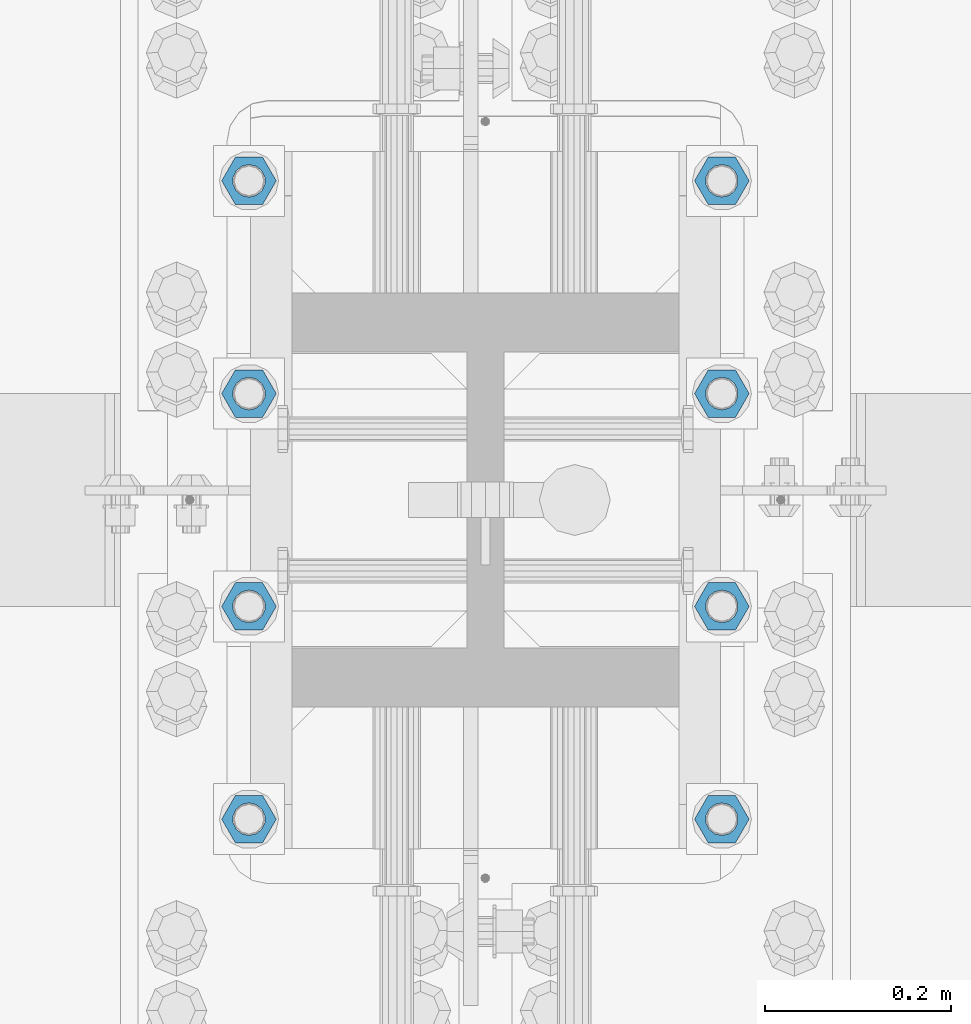
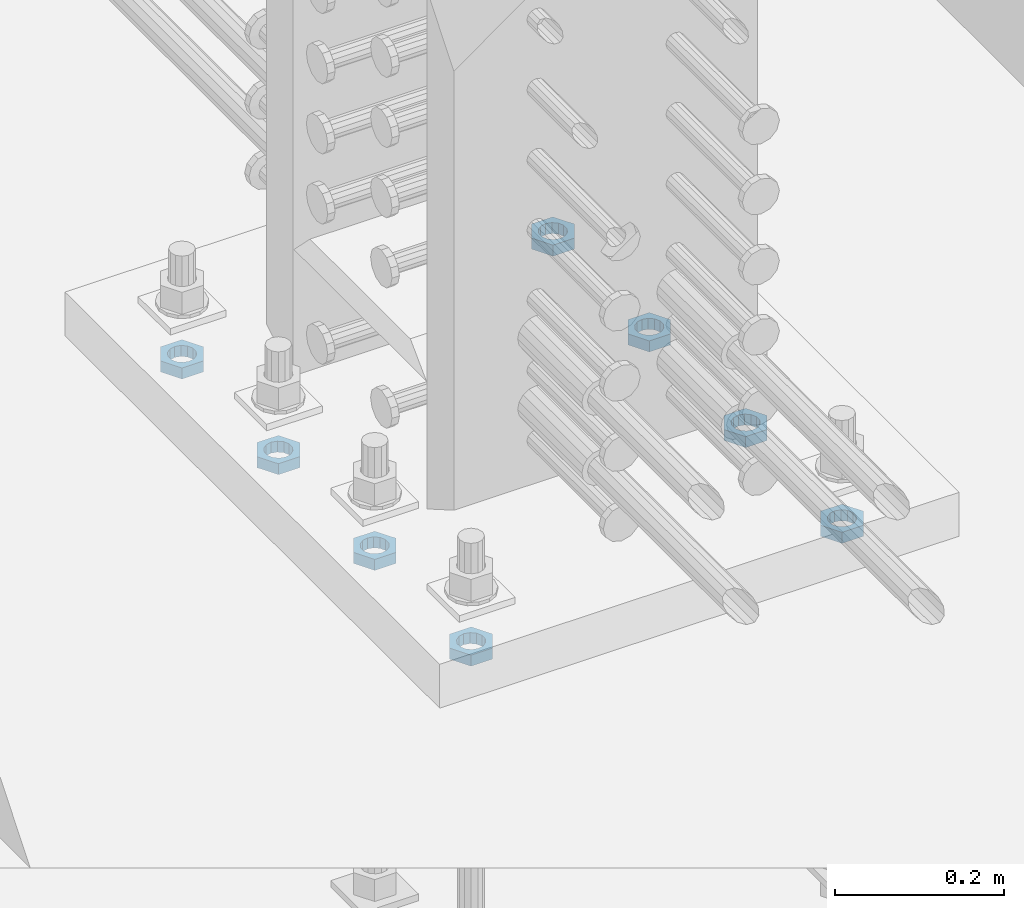
# One storey, part 1401 of 1763: 8 beams, 1 element without a shape of its own.
"""IFC2X3 building model written with IfcOpenShell, lengths in millimetres."""

from ifc_helpers import new_model, si_unit, frame, origin_with_axes, place, context, subcontext, project, spatial, faceted_brep, material, type_object, element, aggregate, save


model = new_model("IFC2X3")

# Units and contexts
model_context = context("Model", 3, precision=1e-05, world=origin_with_axes())
body_context = subcontext(model_context, "Body", "Model", "MODEL_VIEW")
ifc_project = project(units=[si_unit("LENGTHUNIT", "METRE", prefix="MILLI"), si_unit("AREAUNIT", "SQUARE_METRE"), si_unit("VOLUMEUNIT", "CUBIC_METRE"), si_unit("MASSUNIT", "GRAM", prefix="KILO"), si_unit("TIMEUNIT", "SECOND"), si_unit("PLANEANGLEUNIT", "RADIAN"), si_unit("SOLIDANGLEUNIT", "STERADIAN"), si_unit("THERMODYNAMICTEMPERATUREUNIT", "DEGREE_CELSIUS"), si_unit("LUMINOUSINTENSITYUNIT", "LUMEN")], contexts=[model_context])

# Site, building, storey
site_placement = place(None, origin_with_axes())
site = spatial("IfcSite", under=ifc_project, at=site_placement, CompositionType="ELEMENT")
building_placement = place(site_placement, origin_with_axes())
building = spatial("IfcBuilding", under=site, at=building_placement, Name="Undefined", CompositionType="ELEMENT")
storey_placement = place(building_placement, origin_with_axes())
storey = spatial("IfcBuildingStorey", under=building, at=storey_placement, Name="Undefined", CompositionType="ELEMENT", Elevation=0.0)

# Assembly, beams
assembly_placement = place(storey_placement, origin_with_axes())
assembly = element("IfcElementAssembly", 1, at=assembly_placement, inside=storey, Name="TEMPLATE", AssemblyPlace="NOTDEFINED", PredefinedType="RIGID_FRAME")
ifc_material = material(Name="STEEL/A563")
beam_type = type_object("IfcBeamType", Name="1-1/4_DIA. HALF_NUT", PredefinedType="NOTDEFINED")
beam_1_placement = place(assembly_placement, frame((-24281.8372736984, 800.099999999999, 3848.1), z_axis=(0.0, -1.0, 0.0), x_axis=(0.0, 0.0, -1.0)))
beam_1 = element("IfcBeam", 2, at=beam_1_placement, type_object=beam_type, material=ifc_material, Name="NUT", ObjectType="1-1/4_DIA. HALF_NUT", context=body_context, shape_type="Brep", body=[
    faceted_brep([(0.0, -29.3700008392334, 0.0), (0.0, -14.6800003051758, -25.4300003051758), (15.875, -14.6800003051758, -25.4300003051758), (15.875, -29.3700008392334, 0.0), (0.0, 14.6800003051758, -25.4300003051758), (15.875, 14.6800003051758, -25.4300003051758), (0.0, 29.3700008392334, 0.0), (15.875, 29.3700008392334, 0.0), (0.0, 14.6800003051758, 25.4300003051758), (15.875, 14.6800003051758, 25.4300003051758), (0.0, -14.6800003051758, 25.4300003051758), (15.875, -14.6800003051758, 25.4300003051758), (0.0, 0.0, 17.4599990844727), (0.0, 7.57560968776022, 15.730915608714), (15.875, 7.57560968776022, 15.730915608714), (15.875, 0.0, 17.4599990844727), (0.0, 13.6507769681037, 10.8861313696252), (15.875, 13.6507769681037, 10.8861313696252), (0.0, 17.0222404541215, 3.88521530314756), (15.875, 17.0222404541215, 3.88521530314756), (0.0, 17.0222404541215, -3.88521530314756), (15.875, 17.0222404541215, -3.88521530314756), (0.0, 13.6507769681037, -10.8861313696252), (15.875, 13.6507769681037, -10.8861313696252), (0.0, 7.57560968776022, -15.730915608714), (15.875, 7.57560968776022, -15.730915608714), (0.0, 0.0, -17.4599990844727), (15.875, 0.0, -17.4599990844727), (0.0, -7.57560968776022, -15.730915608714), (15.875, -7.57560968776022, -15.730915608714), (0.0, -13.6507769681037, -10.8861313696252), (15.875, -13.6507769681037, -10.8861313696252), (0.0, -17.0222404541215, -3.88521530314756), (15.875, -17.0222404541215, -3.88521530314756), (0.0, -17.0222404541215, 3.88521530314756), (15.875, -17.0222404541215, 3.88521530314756), (0.0, -13.6507769681037, 10.8861313696252), (15.875, -13.6507769681037, 10.8861313696252), (0.0, -7.57560968776022, 15.730915608714), (15.875, -7.57560968776022, 15.730915608714)], [[[0, 1, 2, 3]], [[1, 4, 5, 2]], [[4, 6, 7, 5]], [[6, 8, 9, 7]], [[8, 10, 11, 9]], [[10, 0, 3, 11]], [[12, 13, 14, 15]], [[13, 16, 17, 14]], [[16, 18, 19, 17]], [[18, 20, 21, 19]], [[20, 22, 23, 21]], [[22, 24, 25, 23]], [[24, 26, 27, 25]], [[26, 28, 29, 27]], [[28, 30, 31, 29]], [[30, 32, 33, 31]], [[32, 34, 35, 33]], [[34, 36, 37, 35]], [[36, 38, 39, 37]], [[38, 12, 15, 39]], [[5, 7, 9, 11, 3, 2], [17, 19, 21, 23, 25, 27, 29, 31, 33, 35, 37, 39, 15, 14]], [[10, 8, 6, 4, 1, 0], [38, 36, 34, 32, 30, 28, 26, 24, 22, 20, 18, 16, 13, 12]]]),
])
beam_2_placement = place(assembly_placement, frame((-23773.8372736984, 800.099999999999, 3848.1), z_axis=(0.0, 1.0, 0.0), x_axis=(0.0, 0.0, -1.0)))
beam_2 = element("IfcBeam", 3, at=beam_2_placement, type_object=beam_type, material=ifc_material, Name="NUT", ObjectType="1-1/4_DIA. HALF_NUT", context=body_context, shape_type="Brep", body=[
    faceted_brep([(0.0, -29.3700008392334, 0.0), (0.0, -14.6800003051758, -25.4300003051758), (15.875, -14.6800003051758, -25.4300003051758), (15.875, -29.3700008392334, 0.0), (0.0, 14.6800003051758, -25.4300003051758), (15.875, 14.6800003051758, -25.4300003051758), (0.0, 29.3700008392334, 0.0), (15.875, 29.3700008392334, 0.0), (0.0, 14.6800003051758, 25.4300003051758), (15.875, 14.6800003051758, 25.4300003051758), (0.0, -14.6800003051758, 25.4300003051758), (15.875, -14.6800003051758, 25.4300003051758), (0.0, 0.0, 17.4599990844727), (0.0, 7.57560968776022, 15.730915608714), (15.875, 7.57560968776022, 15.730915608714), (15.875, 0.0, 17.4599990844727), (0.0, 13.6507769681037, 10.8861313696252), (15.875, 13.6507769681037, 10.8861313696252), (0.0, 17.0222404541215, 3.88521530314756), (15.875, 17.0222404541215, 3.88521530314756), (0.0, 17.0222404541215, -3.88521530314756), (15.875, 17.0222404541215, -3.88521530314756), (0.0, 13.6507769681037, -10.8861313696252), (15.875, 13.6507769681037, -10.8861313696252), (0.0, 7.57560968776022, -15.730915608714), (15.875, 7.57560968776022, -15.730915608714), (0.0, 0.0, -17.4599990844727), (15.875, 0.0, -17.4599990844727), (0.0, -7.57560968776022, -15.730915608714), (15.875, -7.57560968776022, -15.730915608714), (0.0, -13.6507769681037, -10.8861313696252), (15.875, -13.6507769681037, -10.8861313696252), (0.0, -17.0222404541215, -3.88521530314756), (15.875, -17.0222404541215, -3.88521530314756), (0.0, -17.0222404541215, 3.88521530314756), (15.875, -17.0222404541215, 3.88521530314756), (0.0, -13.6507769681037, 10.8861313696252), (15.875, -13.6507769681037, 10.8861313696252), (0.0, -7.57560968776022, 15.730915608714), (15.875, -7.57560968776022, 15.730915608714)], [[[0, 1, 2, 3]], [[1, 4, 5, 2]], [[4, 6, 7, 5]], [[6, 8, 9, 7]], [[8, 10, 11, 9]], [[10, 0, 3, 11]], [[12, 13, 14, 15]], [[13, 16, 17, 14]], [[16, 18, 19, 17]], [[18, 20, 21, 19]], [[20, 22, 23, 21]], [[22, 24, 25, 23]], [[24, 26, 27, 25]], [[26, 28, 29, 27]], [[28, 30, 31, 29]], [[30, 32, 33, 31]], [[32, 34, 35, 33]], [[34, 36, 37, 35]], [[36, 38, 39, 37]], [[38, 12, 15, 39]], [[5, 7, 9, 11, 3, 2], [17, 19, 21, 23, 25, 27, 29, 31, 33, 35, 37, 39, 15, 14]], [[10, 8, 6, 4, 1, 0], [38, 36, 34, 32, 30, 28, 26, 24, 22, 20, 18, 16, 13, 12]]]),
])
beam_3_placement = place(assembly_placement, frame((-24281.8372736984, 571.499999999998, 3848.1), z_axis=(0.0, -1.0, 0.0), x_axis=(0.0, 0.0, -1.0)))
beam_3 = element("IfcBeam", 4, at=beam_3_placement, type_object=beam_type, material=ifc_material, Name="NUT", ObjectType="1-1/4_DIA. HALF_NUT", context=body_context, shape_type="Brep", body=[
    faceted_brep([(0.0, -29.3700008392334, 0.0), (0.0, -14.6800003051758, -25.4300003051758), (15.875, -14.6800003051758, -25.4300003051758), (15.875, -29.3700008392334, 0.0), (0.0, 14.6800003051758, -25.4300003051758), (15.875, 14.6800003051758, -25.4300003051758), (0.0, 29.3700008392334, 0.0), (15.875, 29.3700008392334, 0.0), (0.0, 14.6800003051758, 25.4300003051758), (15.875, 14.6800003051758, 25.4300003051758), (0.0, -14.6800003051758, 25.4300003051758), (15.875, -14.6800003051758, 25.4300003051758), (0.0, 0.0, 17.4599990844727), (0.0, 7.57560968776022, 15.730915608714), (15.875, 7.57560968776022, 15.730915608714), (15.875, 0.0, 17.4599990844727), (0.0, 13.6507769681037, 10.8861313696252), (15.875, 13.6507769681037, 10.8861313696252), (0.0, 17.0222404541215, 3.88521530314756), (15.875, 17.0222404541215, 3.88521530314756), (0.0, 17.0222404541215, -3.88521530314756), (15.875, 17.0222404541215, -3.88521530314756), (0.0, 13.6507769681037, -10.8861313696252), (15.875, 13.6507769681037, -10.8861313696252), (0.0, 7.57560968776022, -15.730915608714), (15.875, 7.57560968776022, -15.730915608714), (0.0, 0.0, -17.4599990844727), (15.875, 0.0, -17.4599990844727), (0.0, -7.57560968776022, -15.730915608714), (15.875, -7.57560968776022, -15.730915608714), (0.0, -13.6507769681037, -10.8861313696252), (15.875, -13.6507769681037, -10.8861313696252), (0.0, -17.0222404541215, -3.88521530314756), (15.875, -17.0222404541215, -3.88521530314756), (0.0, -17.0222404541215, 3.88521530314756), (15.875, -17.0222404541215, 3.88521530314756), (0.0, -13.6507769681037, 10.8861313696252), (15.875, -13.6507769681037, 10.8861313696252), (0.0, -7.57560968776022, 15.730915608714), (15.875, -7.57560968776022, 15.730915608714)], [[[0, 1, 2, 3]], [[1, 4, 5, 2]], [[4, 6, 7, 5]], [[6, 8, 9, 7]], [[8, 10, 11, 9]], [[10, 0, 3, 11]], [[12, 13, 14, 15]], [[13, 16, 17, 14]], [[16, 18, 19, 17]], [[18, 20, 21, 19]], [[20, 22, 23, 21]], [[22, 24, 25, 23]], [[24, 26, 27, 25]], [[26, 28, 29, 27]], [[28, 30, 31, 29]], [[30, 32, 33, 31]], [[32, 34, 35, 33]], [[34, 36, 37, 35]], [[36, 38, 39, 37]], [[38, 12, 15, 39]], [[5, 7, 9, 11, 3, 2], [17, 19, 21, 23, 25, 27, 29, 31, 33, 35, 37, 39, 15, 14]], [[10, 8, 6, 4, 1, 0], [38, 36, 34, 32, 30, 28, 26, 24, 22, 20, 18, 16, 13, 12]]]),
])
beam_4_placement = place(assembly_placement, frame((-23773.8372736984, 571.499999999998, 3848.1), z_axis=(0.0, 1.0, 0.0), x_axis=(0.0, 0.0, -1.0)))
beam_4 = element("IfcBeam", 5, at=beam_4_placement, type_object=beam_type, material=ifc_material, Name="NUT", ObjectType="1-1/4_DIA. HALF_NUT", context=body_context, shape_type="Brep", body=[
    faceted_brep([(0.0, -29.3700008392334, 0.0), (0.0, -14.6800003051758, -25.4300003051758), (15.875, -14.6800003051758, -25.4300003051758), (15.875, -29.3700008392334, 0.0), (0.0, 14.6800003051758, -25.4300003051758), (15.875, 14.6800003051758, -25.4300003051758), (0.0, 29.3700008392334, 0.0), (15.875, 29.3700008392334, 0.0), (0.0, 14.6800003051758, 25.4300003051758), (15.875, 14.6800003051758, 25.4300003051758), (0.0, -14.6800003051758, 25.4300003051758), (15.875, -14.6800003051758, 25.4300003051758), (0.0, 0.0, 17.4599990844727), (0.0, 7.57560968776022, 15.730915608714), (15.875, 7.57560968776022, 15.730915608714), (15.875, 0.0, 17.4599990844727), (0.0, 13.6507769681037, 10.8861313696252), (15.875, 13.6507769681037, 10.8861313696252), (0.0, 17.0222404541215, 3.88521530314756), (15.875, 17.0222404541215, 3.88521530314756), (0.0, 17.0222404541215, -3.88521530314756), (15.875, 17.0222404541215, -3.88521530314756), (0.0, 13.6507769681037, -10.8861313696252), (15.875, 13.6507769681037, -10.8861313696252), (0.0, 7.57560968776022, -15.730915608714), (15.875, 7.57560968776022, -15.730915608714), (0.0, 0.0, -17.4599990844727), (15.875, 0.0, -17.4599990844727), (0.0, -7.57560968776022, -15.730915608714), (15.875, -7.57560968776022, -15.730915608714), (0.0, -13.6507769681037, -10.8861313696252), (15.875, -13.6507769681037, -10.8861313696252), (0.0, -17.0222404541215, -3.88521530314756), (15.875, -17.0222404541215, -3.88521530314756), (0.0, -17.0222404541215, 3.88521530314756), (15.875, -17.0222404541215, 3.88521530314756), (0.0, -13.6507769681037, 10.8861313696252), (15.875, -13.6507769681037, 10.8861313696252), (0.0, -7.57560968776022, 15.730915608714), (15.875, -7.57560968776022, 15.730915608714)], [[[0, 1, 2, 3]], [[1, 4, 5, 2]], [[4, 6, 7, 5]], [[6, 8, 9, 7]], [[8, 10, 11, 9]], [[10, 0, 3, 11]], [[12, 13, 14, 15]], [[13, 16, 17, 14]], [[16, 18, 19, 17]], [[18, 20, 21, 19]], [[20, 22, 23, 21]], [[22, 24, 25, 23]], [[24, 26, 27, 25]], [[26, 28, 29, 27]], [[28, 30, 31, 29]], [[30, 32, 33, 31]], [[32, 34, 35, 33]], [[34, 36, 37, 35]], [[36, 38, 39, 37]], [[38, 12, 15, 39]], [[5, 7, 9, 11, 3, 2], [17, 19, 21, 23, 25, 27, 29, 31, 33, 35, 37, 39, 15, 14]], [[10, 8, 6, 4, 1, 0], [38, 36, 34, 32, 30, 28, 26, 24, 22, 20, 18, 16, 13, 12]]]),
])
beam_5_placement = place(assembly_placement, frame((-23773.8372736984, 342.899999999998, 3848.1), z_axis=(0.0, 1.0, 0.0), x_axis=(0.0, 0.0, -1.0)))
beam_5 = element("IfcBeam", 6, at=beam_5_placement, type_object=beam_type, material=ifc_material, Name="NUT", ObjectType="1-1/4_DIA. HALF_NUT", context=body_context, shape_type="Brep", body=[
    faceted_brep([(0.0, -29.3700008392334, 0.0), (0.0, -14.6800003051758, -25.4300003051758), (15.875, -14.6800003051758, -25.4300003051758), (15.875, -29.3700008392334, 0.0), (0.0, 14.6800003051758, -25.4300003051758), (15.875, 14.6800003051758, -25.4300003051758), (0.0, 29.3700008392334, 0.0), (15.875, 29.3700008392334, 0.0), (0.0, 14.6800003051758, 25.4300003051758), (15.875, 14.6800003051758, 25.4300003051758), (0.0, -14.6800003051758, 25.4300003051758), (15.875, -14.6800003051758, 25.4300003051758), (0.0, 0.0, 17.4599990844727), (0.0, 7.57560968776022, 15.730915608714), (15.875, 7.57560968776022, 15.730915608714), (15.875, 0.0, 17.4599990844727), (0.0, 13.6507769681037, 10.8861313696252), (15.875, 13.6507769681037, 10.8861313696252), (0.0, 17.0222404541215, 3.88521530314756), (15.875, 17.0222404541215, 3.88521530314756), (0.0, 17.0222404541215, -3.88521530314756), (15.875, 17.0222404541215, -3.88521530314756), (0.0, 13.6507769681037, -10.8861313696252), (15.875, 13.6507769681037, -10.8861313696252), (0.0, 7.57560968776022, -15.730915608714), (15.875, 7.57560968776022, -15.730915608714), (0.0, 0.0, -17.4599990844727), (15.875, 0.0, -17.4599990844727), (0.0, -7.57560968776022, -15.730915608714), (15.875, -7.57560968776022, -15.730915608714), (0.0, -13.6507769681037, -10.8861313696252), (15.875, -13.6507769681037, -10.8861313696252), (0.0, -17.0222404541215, -3.88521530314756), (15.875, -17.0222404541215, -3.88521530314756), (0.0, -17.0222404541215, 3.88521530314756), (15.875, -17.0222404541215, 3.88521530314756), (0.0, -13.6507769681037, 10.8861313696252), (15.875, -13.6507769681037, 10.8861313696252), (0.0, -7.57560968776022, 15.730915608714), (15.875, -7.57560968776022, 15.730915608714)], [[[0, 1, 2, 3]], [[1, 4, 5, 2]], [[4, 6, 7, 5]], [[6, 8, 9, 7]], [[8, 10, 11, 9]], [[10, 0, 3, 11]], [[12, 13, 14, 15]], [[13, 16, 17, 14]], [[16, 18, 19, 17]], [[18, 20, 21, 19]], [[20, 22, 23, 21]], [[22, 24, 25, 23]], [[24, 26, 27, 25]], [[26, 28, 29, 27]], [[28, 30, 31, 29]], [[30, 32, 33, 31]], [[32, 34, 35, 33]], [[34, 36, 37, 35]], [[36, 38, 39, 37]], [[38, 12, 15, 39]], [[5, 7, 9, 11, 3, 2], [17, 19, 21, 23, 25, 27, 29, 31, 33, 35, 37, 39, 15, 14]], [[10, 8, 6, 4, 1, 0], [38, 36, 34, 32, 30, 28, 26, 24, 22, 20, 18, 16, 13, 12]]]),
])
beam_6_placement = place(assembly_placement, frame((-24281.8372736984, 342.899999999998, 3848.1), z_axis=(0.0, -1.0, 0.0), x_axis=(0.0, 0.0, -1.0)))
beam_6 = element("IfcBeam", 7, at=beam_6_placement, type_object=beam_type, material=ifc_material, Name="NUT", ObjectType="1-1/4_DIA. HALF_NUT", context=body_context, shape_type="Brep", body=[
    faceted_brep([(0.0, -29.3700008392334, 0.0), (0.0, -14.6800003051758, -25.4300003051758), (15.875, -14.6800003051758, -25.4300003051758), (15.875, -29.3700008392334, 0.0), (0.0, 14.6800003051758, -25.4300003051758), (15.875, 14.6800003051758, -25.4300003051758), (0.0, 29.3700008392334, 0.0), (15.875, 29.3700008392334, 0.0), (0.0, 14.6800003051758, 25.4300003051758), (15.875, 14.6800003051758, 25.4300003051758), (0.0, -14.6800003051758, 25.4300003051758), (15.875, -14.6800003051758, 25.4300003051758), (0.0, 0.0, 17.4599990844727), (0.0, 7.57560968776022, 15.730915608714), (15.875, 7.57560968776022, 15.730915608714), (15.875, 0.0, 17.4599990844727), (0.0, 13.6507769681037, 10.8861313696252), (15.875, 13.6507769681037, 10.8861313696252), (0.0, 17.0222404541215, 3.88521530314756), (15.875, 17.0222404541215, 3.88521530314756), (0.0, 17.0222404541215, -3.88521530314756), (15.875, 17.0222404541215, -3.88521530314756), (0.0, 13.6507769681037, -10.8861313696252), (15.875, 13.6507769681037, -10.8861313696252), (0.0, 7.57560968776022, -15.730915608714), (15.875, 7.57560968776022, -15.730915608714), (0.0, 0.0, -17.4599990844727), (15.875, 0.0, -17.4599990844727), (0.0, -7.57560968776022, -15.730915608714), (15.875, -7.57560968776022, -15.730915608714), (0.0, -13.6507769681037, -10.8861313696252), (15.875, -13.6507769681037, -10.8861313696252), (0.0, -17.0222404541215, -3.88521530314756), (15.875, -17.0222404541215, -3.88521530314756), (0.0, -17.0222404541215, 3.88521530314756), (15.875, -17.0222404541215, 3.88521530314756), (0.0, -13.6507769681037, 10.8861313696252), (15.875, -13.6507769681037, 10.8861313696252), (0.0, -7.57560968776022, 15.730915608714), (15.875, -7.57560968776022, 15.730915608714)], [[[0, 1, 2, 3]], [[1, 4, 5, 2]], [[4, 6, 7, 5]], [[6, 8, 9, 7]], [[8, 10, 11, 9]], [[10, 0, 3, 11]], [[12, 13, 14, 15]], [[13, 16, 17, 14]], [[16, 18, 19, 17]], [[18, 20, 21, 19]], [[20, 22, 23, 21]], [[22, 24, 25, 23]], [[24, 26, 27, 25]], [[26, 28, 29, 27]], [[28, 30, 31, 29]], [[30, 32, 33, 31]], [[32, 34, 35, 33]], [[34, 36, 37, 35]], [[36, 38, 39, 37]], [[38, 12, 15, 39]], [[5, 7, 9, 11, 3, 2], [17, 19, 21, 23, 25, 27, 29, 31, 33, 35, 37, 39, 15, 14]], [[10, 8, 6, 4, 1, 0], [38, 36, 34, 32, 30, 28, 26, 24, 22, 20, 18, 16, 13, 12]]]),
])
beam_7_placement = place(assembly_placement, frame((-24281.8372736984, 114.299999999997, 3848.1), z_axis=(0.0, -1.0, 0.0), x_axis=(0.0, 0.0, -1.0)))
beam_7 = element("IfcBeam", 8, at=beam_7_placement, type_object=beam_type, material=ifc_material, Name="NUT", ObjectType="1-1/4_DIA. HALF_NUT", context=body_context, shape_type="Brep", body=[
    faceted_brep([(0.0, -29.3700008392334, 0.0), (0.0, -14.6800003051758, -25.4300003051758), (15.875, -14.6800003051758, -25.4300003051758), (15.875, -29.3700008392334, 0.0), (0.0, 14.6800003051758, -25.4300003051758), (15.875, 14.6800003051758, -25.4300003051758), (0.0, 29.3700008392334, 0.0), (15.875, 29.3700008392334, 0.0), (0.0, 14.6800003051758, 25.4300003051758), (15.875, 14.6800003051758, 25.4300003051758), (0.0, -14.6800003051758, 25.4300003051758), (15.875, -14.6800003051758, 25.4300003051758), (0.0, 0.0, 17.4599990844727), (0.0, 7.57560968776022, 15.730915608714), (15.875, 7.57560968776022, 15.730915608714), (15.875, 0.0, 17.4599990844727), (0.0, 13.6507769681037, 10.8861313696252), (15.875, 13.6507769681037, 10.8861313696252), (0.0, 17.0222404541215, 3.88521530314756), (15.875, 17.0222404541215, 3.88521530314756), (0.0, 17.0222404541215, -3.88521530314756), (15.875, 17.0222404541215, -3.88521530314756), (0.0, 13.6507769681037, -10.8861313696252), (15.875, 13.6507769681037, -10.8861313696252), (0.0, 7.57560968776022, -15.730915608714), (15.875, 7.57560968776022, -15.730915608714), (0.0, 0.0, -17.4599990844727), (15.875, 0.0, -17.4599990844727), (0.0, -7.57560968776022, -15.730915608714), (15.875, -7.57560968776022, -15.730915608714), (0.0, -13.6507769681037, -10.8861313696252), (15.875, -13.6507769681037, -10.8861313696252), (0.0, -17.0222404541215, -3.88521530314756), (15.875, -17.0222404541215, -3.88521530314756), (0.0, -17.0222404541215, 3.88521530314756), (15.875, -17.0222404541215, 3.88521530314756), (0.0, -13.6507769681037, 10.8861313696252), (15.875, -13.6507769681037, 10.8861313696252), (0.0, -7.57560968776022, 15.730915608714), (15.875, -7.57560968776022, 15.730915608714)], [[[0, 1, 2, 3]], [[1, 4, 5, 2]], [[4, 6, 7, 5]], [[6, 8, 9, 7]], [[8, 10, 11, 9]], [[10, 0, 3, 11]], [[12, 13, 14, 15]], [[13, 16, 17, 14]], [[16, 18, 19, 17]], [[18, 20, 21, 19]], [[20, 22, 23, 21]], [[22, 24, 25, 23]], [[24, 26, 27, 25]], [[26, 28, 29, 27]], [[28, 30, 31, 29]], [[30, 32, 33, 31]], [[32, 34, 35, 33]], [[34, 36, 37, 35]], [[36, 38, 39, 37]], [[38, 12, 15, 39]], [[5, 7, 9, 11, 3, 2], [17, 19, 21, 23, 25, 27, 29, 31, 33, 35, 37, 39, 15, 14]], [[10, 8, 6, 4, 1, 0], [38, 36, 34, 32, 30, 28, 26, 24, 22, 20, 18, 16, 13, 12]]]),
])
beam_8_placement = place(assembly_placement, frame((-23773.8372736984, 114.299999999997, 3848.1), z_axis=(0.0, 1.0, 0.0), x_axis=(0.0, 0.0, -1.0)))
beam_8 = element("IfcBeam", 9, at=beam_8_placement, type_object=beam_type, material=ifc_material, Name="NUT", ObjectType="1-1/4_DIA. HALF_NUT", context=body_context, shape_type="Brep", body=[
    faceted_brep([(0.0, -29.3700008392334, 0.0), (0.0, -14.6800003051758, -25.4300003051758), (15.875, -14.6800003051758, -25.4300003051758), (15.875, -29.3700008392334, 0.0), (0.0, 14.6800003051758, -25.4300003051758), (15.875, 14.6800003051758, -25.4300003051758), (0.0, 29.3700008392334, 0.0), (15.875, 29.3700008392334, 0.0), (0.0, 14.6800003051758, 25.4300003051758), (15.875, 14.6800003051758, 25.4300003051758), (0.0, -14.6800003051758, 25.4300003051758), (15.875, -14.6800003051758, 25.4300003051758), (0.0, 0.0, 17.4599990844727), (0.0, 7.57560968776022, 15.730915608714), (15.875, 7.57560968776022, 15.730915608714), (15.875, 0.0, 17.4599990844727), (0.0, 13.6507769681037, 10.8861313696252), (15.875, 13.6507769681037, 10.8861313696252), (0.0, 17.0222404541215, 3.88521530314756), (15.875, 17.0222404541215, 3.88521530314756), (0.0, 17.0222404541215, -3.88521530314756), (15.875, 17.0222404541215, -3.88521530314756), (0.0, 13.6507769681037, -10.8861313696252), (15.875, 13.6507769681037, -10.8861313696252), (0.0, 7.57560968776022, -15.730915608714), (15.875, 7.57560968776022, -15.730915608714), (0.0, 0.0, -17.4599990844727), (15.875, 0.0, -17.4599990844727), (0.0, -7.57560968776022, -15.730915608714), (15.875, -7.57560968776022, -15.730915608714), (0.0, -13.6507769681037, -10.8861313696252), (15.875, -13.6507769681037, -10.8861313696252), (0.0, -17.0222404541215, -3.88521530314756), (15.875, -17.0222404541215, -3.88521530314756), (0.0, -17.0222404541215, 3.88521530314756), (15.875, -17.0222404541215, 3.88521530314756), (0.0, -13.6507769681037, 10.8861313696252), (15.875, -13.6507769681037, 10.8861313696252), (0.0, -7.57560968776022, 15.730915608714), (15.875, -7.57560968776022, 15.730915608714)], [[[0, 1, 2, 3]], [[1, 4, 5, 2]], [[4, 6, 7, 5]], [[6, 8, 9, 7]], [[8, 10, 11, 9]], [[10, 0, 3, 11]], [[12, 13, 14, 15]], [[13, 16, 17, 14]], [[16, 18, 19, 17]], [[18, 20, 21, 19]], [[20, 22, 23, 21]], [[22, 24, 25, 23]], [[24, 26, 27, 25]], [[26, 28, 29, 27]], [[28, 30, 31, 29]], [[30, 32, 33, 31]], [[32, 34, 35, 33]], [[34, 36, 37, 35]], [[36, 38, 39, 37]], [[38, 12, 15, 39]], [[5, 7, 9, 11, 3, 2], [17, 19, 21, 23, 25, 27, 29, 31, 33, 35, 37, 39, 15, 14]], [[10, 8, 6, 4, 1, 0], [38, 36, 34, 32, 30, 28, 26, 24, 22, 20, 18, 16, 13, 12]]]),
])
aggregate(assembly, [beam_1, beam_2, beam_3, beam_4, beam_5, beam_6, beam_7, beam_8])

save(model, "model.ifc")
